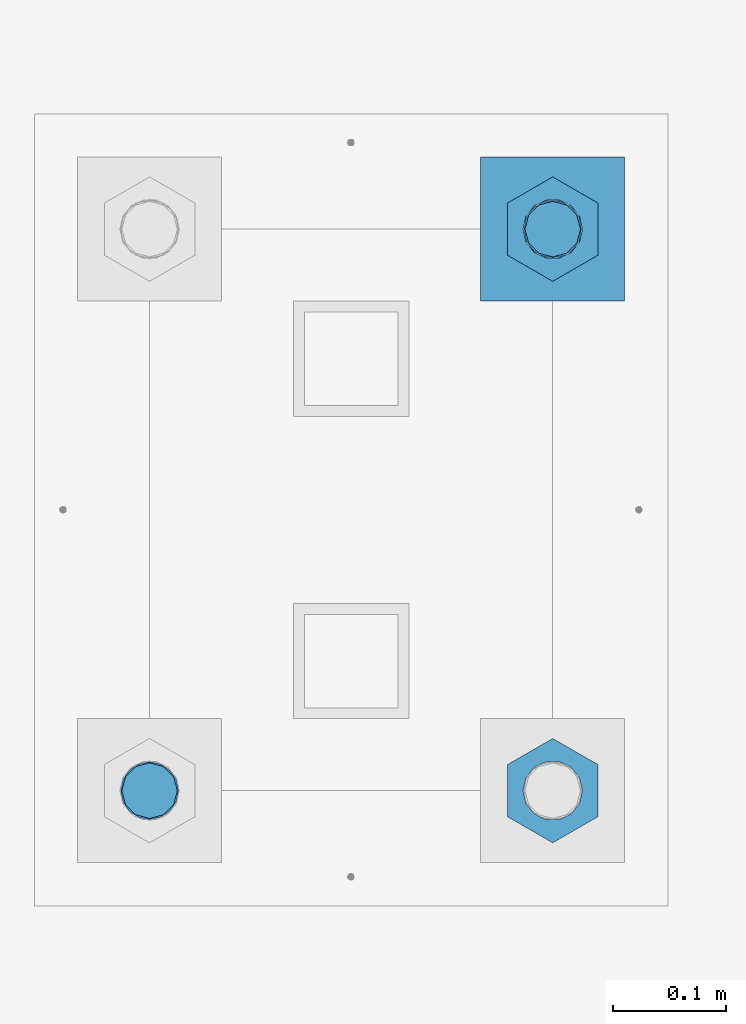
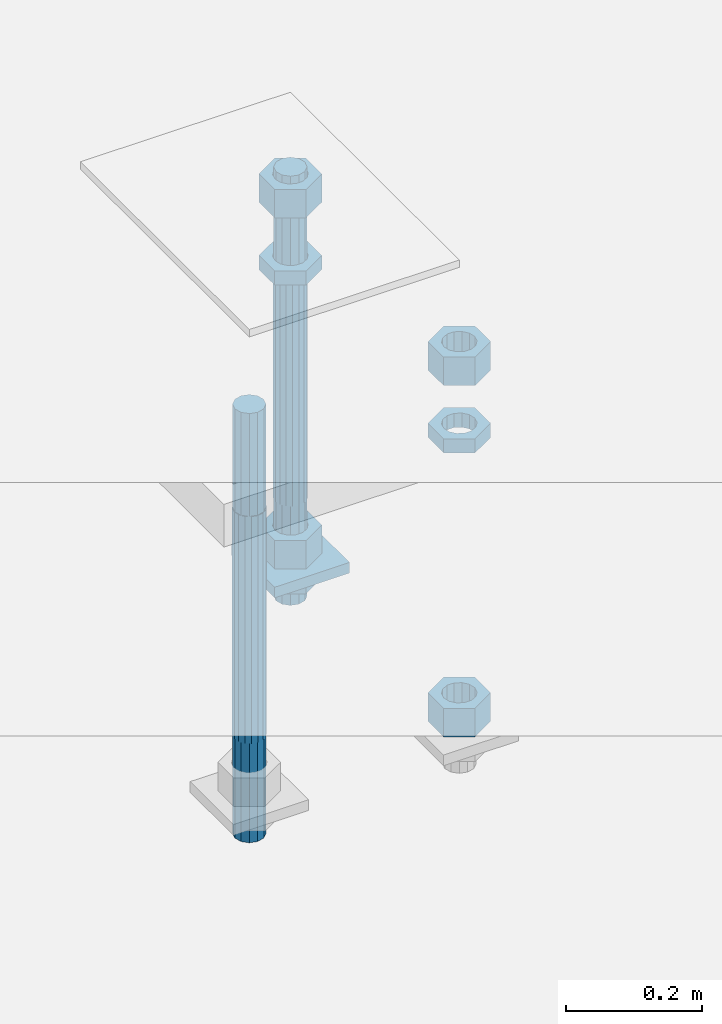
# One storey, part 2614 of 3843: 10 beams, 1 element without a shape of its own.
"""IFC2X3 building model written with IfcOpenShell, lengths in millimetres."""

from ifc_helpers import new_model, si_unit, frame, origin_with_axes, place, context, subcontext, project, spatial, faceted_brep, material, type_object, element, aggregate, save


model = new_model("IFC2X3")

# Units and contexts
model_context = context("Model", 3, precision=1e-05, world=origin_with_axes())
body_context = subcontext(model_context, "Body", "Model", "MODEL_VIEW")
ifc_project = project(units=[si_unit("LENGTHUNIT", "METRE", prefix="MILLI"), si_unit("AREAUNIT", "SQUARE_METRE"), si_unit("VOLUMEUNIT", "CUBIC_METRE"), si_unit("MASSUNIT", "GRAM", prefix="KILO"), si_unit("TIMEUNIT", "SECOND"), si_unit("PLANEANGLEUNIT", "RADIAN"), si_unit("SOLIDANGLEUNIT", "STERADIAN"), si_unit("THERMODYNAMICTEMPERATUREUNIT", "DEGREE_CELSIUS"), si_unit("LUMINOUSINTENSITYUNIT", "LUMEN")], contexts=[model_context])

# Site, building, storey
site_placement = place(None, origin_with_axes())
site = spatial("IfcSite", under=ifc_project, at=site_placement, CompositionType="ELEMENT")
building_placement = place(site_placement, origin_with_axes())
building = spatial("IfcBuilding", under=site, at=building_placement, Name="Undefined", CompositionType="ELEMENT")
storey_placement = place(building_placement, origin_with_axes())
storey = spatial("IfcBuildingStorey", under=building, at=storey_placement, Name="Undefined", CompositionType="ELEMENT", Elevation=0.0)

# Assembly, beams
assembly_placement = place(storey_placement, origin_with_axes())
assembly = element("IfcElementAssembly", 1, at=assembly_placement, inside=storey, Name="TEMPLATE", AssemblyPlace="NOTDEFINED", PredefinedType="RIGID_FRAME")
ifc_material_1 = material(Name="STEEL/A572-50")
beam_type_1 = type_object("IfcBeamType", PredefinedType="NOTDEFINED")
beam_1_placement = place(assembly_placement, frame((112153.700001526, 247.649999999994, 29244.925), z_axis=(0.0, -1.0, 0.0), x_axis=(1.0, 0.0, 0.0)))
beam_1 = element("IfcBeam", 2, at=beam_1_placement, type_object=beam_type_1, material=ifc_material_1, Name="WASHER_PLATE", context=body_context, shape_type="Brep", body=[
    faceted_brep([(0.0, 9.52500000000146, -63.5), (0.0, 9.52500000000146, 63.5), (127.0, 9.52500000000146, 63.5), (127.0, 9.52500000000146, -63.5), (0.0, -9.52500000000146, 63.5), (127.0, -9.52500000000146, 63.5), (0.0, -9.52500000000146, -63.5), (127.0, -9.52500000000146, -63.5)], [[[0, 1, 2, 3]], [[1, 4, 5, 2]], [[4, 6, 7, 5]], [[6, 0, 3, 7]], [[5, 7, 3, 2]], [[6, 4, 1, 0]]]),
])
ifc_material_2 = material(Name="STEEL/A36")
beam_type_2 = type_object("IfcBeamType", Name="2_HALF_NUT", PredefinedType="NOTDEFINED")
beam_2_placement = place(assembly_placement, frame((112217.200001526, 247.649999999994, 29787.85), z_axis=(1.0, 0.0, 0.0), x_axis=(0.0, 0.0, -1.0)))
beam_2 = element("IfcBeam", 3, at=beam_2_placement, type_object=beam_type_2, material=ifc_material_2, Name="NUT", ObjectType="2_HALF_NUT", context=body_context, shape_type="Brep", body=[
    faceted_brep([(0.0, -46.0369987487793, 0.0), (0.0, -23.0184993743896, -39.869213104248), (25.4000000000015, -23.0184993743896, -39.869213104248), (25.4000000000015, -46.0369987487793, 0.0), (0.0, 23.0184993743896, -39.869213104248), (25.4000000000015, 23.0184993743896, -39.869213104248), (0.0, 46.0369987487793, 0.0), (25.4000000000015, 46.0369987487793, 0.0), (0.0, 23.0184993743896, 39.869213104248), (25.4000000000015, 23.0184993743896, 39.869213104248), (0.0, -23.0184993743896, 39.869213104248), (25.4000000000015, -23.0184993743896, 39.869213104248), (0.0, 0.0, 26.1940002441406), (0.0, 11.3650617044477, 23.5999013092805), (25.4000000000015, 11.3650617044477, 23.5999013092805), (25.4000000000015, 0.0, 26.1940002441406), (0.0, 20.4791109456419, 16.3316083006721), (25.4000000000015, 20.4791109456419, 16.3316083006721), (0.0, 25.5370200498292, 5.82867859874386), (25.4000000000015, 25.5370200498292, 5.82867859874386), (0.0, 25.5370200498292, -5.82867859874386), (25.4000000000015, 25.5370200498292, -5.82867859874386), (0.0, 20.4791109456419, -16.3316083006721), (25.4000000000015, 20.4791109456419, -16.3316083006721), (0.0, 11.3650617044477, -23.5999013092805), (25.4000000000015, 11.3650617044477, -23.5999013092805), (0.0, 0.0, -26.1940002441406), (25.4000000000015, 0.0, -26.1940002441406), (0.0, -11.3650617044477, -23.5999013092805), (25.4000000000015, -11.3650617044477, -23.5999013092805), (0.0, -20.4791109456419, -16.3316083006721), (25.4000000000015, -20.4791109456419, -16.3316083006721), (0.0, -25.5370200498292, -5.82867859874386), (25.4000000000015, -25.5370200498292, -5.82867859874386), (0.0, -25.5370200498292, 5.82867859874386), (25.4000000000015, -25.5370200498292, 5.82867859874386), (0.0, -20.4791109456419, 16.3316083006721), (25.4000000000015, -20.4791109456419, 16.3316083006721), (0.0, -11.3650617044477, 23.5999013092805), (25.4000000000015, -11.3650617044477, 23.5999013092805)], [[[0, 1, 2, 3]], [[1, 4, 5, 2]], [[4, 6, 7, 5]], [[6, 8, 9, 7]], [[8, 10, 11, 9]], [[10, 0, 3, 11]], [[12, 13, 14, 15]], [[13, 16, 17, 14]], [[16, 18, 19, 17]], [[18, 20, 21, 19]], [[20, 22, 23, 21]], [[22, 24, 25, 23]], [[24, 26, 27, 25]], [[26, 28, 29, 27]], [[28, 30, 31, 29]], [[30, 32, 33, 31]], [[32, 34, 35, 33]], [[34, 36, 37, 35]], [[36, 38, 39, 37]], [[38, 12, 15, 39]], [[5, 7, 9, 11, 3, 2], [17, 19, 21, 23, 25, 27, 29, 31, 33, 35, 37, 39, 15, 14]], [[10, 8, 6, 4, 1, 0], [38, 36, 34, 32, 30, 28, 26, 24, 22, 20, 18, 16, 13, 12]]]),
])
beam_3_placement = place(assembly_placement, frame((112217.200001526, 247.649999999994, 29235.4), z_axis=(1.0, 0.0, 0.0), x_axis=(0.0, 0.0, -1.0)))
beam_3 = element("IfcBeam", 4, at=beam_3_placement, type_object=beam_type_2, material=ifc_material_2, Name="NUT", ObjectType="2_HALF_NUT", context=body_context, shape_type="Brep", body=[
    faceted_brep([(0.0, -46.0369987487793, 0.0), (0.0, -23.0184993743896, -39.869213104248), (25.4000000000015, -23.0184993743896, -39.869213104248), (25.4000000000015, -46.0369987487793, 0.0), (0.0, 23.0184993743896, -39.869213104248), (25.4000000000015, 23.0184993743896, -39.869213104248), (0.0, 46.0369987487793, 0.0), (25.4000000000015, 46.0369987487793, 0.0), (0.0, 23.0184993743896, 39.869213104248), (25.4000000000015, 23.0184993743896, 39.869213104248), (0.0, -23.0184993743896, 39.869213104248), (25.4000000000015, -23.0184993743896, 39.869213104248), (0.0, 0.0, 26.1940002441406), (0.0, 11.3650617044477, 23.5999013092805), (25.4000000000015, 11.3650617044477, 23.5999013092805), (25.4000000000015, 0.0, 26.1940002441406), (0.0, 20.4791109456419, 16.3316083006721), (25.4000000000015, 20.4791109456419, 16.3316083006721), (0.0, 25.5370200498292, 5.82867859874386), (25.4000000000015, 25.5370200498292, 5.82867859874386), (0.0, 25.5370200498292, -5.82867859874386), (25.4000000000015, 25.5370200498292, -5.82867859874386), (0.0, 20.4791109456419, -16.3316083006721), (25.4000000000015, 20.4791109456419, -16.3316083006721), (0.0, 11.3650617044477, -23.5999013092805), (25.4000000000015, 11.3650617044477, -23.5999013092805), (0.0, 0.0, -26.1940002441406), (25.4000000000015, 0.0, -26.1940002441406), (0.0, -11.3650617044477, -23.5999013092805), (25.4000000000015, -11.3650617044477, -23.5999013092805), (0.0, -20.4791109456419, -16.3316083006721), (25.4000000000015, -20.4791109456419, -16.3316083006721), (0.0, -25.5370200498292, -5.82867859874386), (25.4000000000015, -25.5370200498292, -5.82867859874386), (0.0, -25.5370200498292, 5.82867859874386), (25.4000000000015, -25.5370200498292, 5.82867859874386), (0.0, -20.4791109456419, 16.3316083006721), (25.4000000000015, -20.4791109456419, 16.3316083006721), (0.0, -11.3650617044477, 23.5999013092805), (25.4000000000015, -11.3650617044477, 23.5999013092805)], [[[0, 1, 2, 3]], [[1, 4, 5, 2]], [[4, 6, 7, 5]], [[6, 8, 9, 7]], [[8, 10, 11, 9]], [[10, 0, 3, 11]], [[12, 13, 14, 15]], [[13, 16, 17, 14]], [[16, 18, 19, 17]], [[18, 20, 21, 19]], [[20, 22, 23, 21]], [[22, 24, 25, 23]], [[24, 26, 27, 25]], [[26, 28, 29, 27]], [[28, 30, 31, 29]], [[30, 32, 33, 31]], [[32, 34, 35, 33]], [[34, 36, 37, 35]], [[36, 38, 39, 37]], [[38, 12, 15, 39]], [[5, 7, 9, 11, 3, 2], [17, 19, 21, 23, 25, 27, 29, 31, 33, 35, 37, 39, 15, 14]], [[10, 8, 6, 4, 1, 0], [38, 36, 34, 32, 30, 28, 26, 24, 22, 20, 18, 16, 13, 12]]]),
])
beam_4_placement = place(assembly_placement, frame((112217.200001526, -247.649999999994, 29787.85), z_axis=(1.0, 0.0, 0.0), x_axis=(0.0, 0.0, -1.0)))
beam_4 = element("IfcBeam", 5, at=beam_4_placement, type_object=beam_type_2, material=ifc_material_2, Name="NUT", ObjectType="2_HALF_NUT", context=body_context, shape_type="Brep", body=[
    faceted_brep([(0.0, -46.0369987487793, 0.0), (0.0, -23.0184993743896, -39.869213104248), (25.4000000000015, -23.0184993743896, -39.869213104248), (25.4000000000015, -46.0369987487793, 0.0), (0.0, 23.0184993743896, -39.869213104248), (25.4000000000015, 23.0184993743896, -39.869213104248), (0.0, 46.0369987487793, 0.0), (25.4000000000015, 46.0369987487793, 0.0), (0.0, 23.0184993743896, 39.869213104248), (25.4000000000015, 23.0184993743896, 39.869213104248), (0.0, -23.0184993743896, 39.869213104248), (25.4000000000015, -23.0184993743896, 39.869213104248), (0.0, 0.0, 26.1940002441406), (0.0, 11.3650617044477, 23.5999013092805), (25.4000000000015, 11.3650617044477, 23.5999013092805), (25.4000000000015, 0.0, 26.1940002441406), (0.0, 20.4791109456419, 16.3316083006721), (25.4000000000015, 20.4791109456419, 16.3316083006721), (0.0, 25.5370200498292, 5.82867859874386), (25.4000000000015, 25.5370200498292, 5.82867859874386), (0.0, 25.5370200498292, -5.82867859874386), (25.4000000000015, 25.5370200498292, -5.82867859874386), (0.0, 20.4791109456419, -16.3316083006721), (25.4000000000015, 20.4791109456419, -16.3316083006721), (0.0, 11.3650617044477, -23.5999013092805), (25.4000000000015, 11.3650617044477, -23.5999013092805), (0.0, 0.0, -26.1940002441406), (25.4000000000015, 0.0, -26.1940002441406), (0.0, -11.3650617044477, -23.5999013092805), (25.4000000000015, -11.3650617044477, -23.5999013092805), (0.0, -20.4791109456419, -16.3316083006721), (25.4000000000015, -20.4791109456419, -16.3316083006721), (0.0, -25.5370200498292, -5.82867859874386), (25.4000000000015, -25.5370200498292, -5.82867859874386), (0.0, -25.5370200498292, 5.82867859874386), (25.4000000000015, -25.5370200498292, 5.82867859874386), (0.0, -20.4791109456419, 16.3316083006721), (25.4000000000015, -20.4791109456419, 16.3316083006721), (0.0, -11.3650617044477, 23.5999013092805), (25.4000000000015, -11.3650617044477, 23.5999013092805)], [[[0, 1, 2, 3]], [[1, 4, 5, 2]], [[4, 6, 7, 5]], [[6, 8, 9, 7]], [[8, 10, 11, 9]], [[10, 0, 3, 11]], [[12, 13, 14, 15]], [[13, 16, 17, 14]], [[16, 18, 19, 17]], [[18, 20, 21, 19]], [[20, 22, 23, 21]], [[22, 24, 25, 23]], [[24, 26, 27, 25]], [[26, 28, 29, 27]], [[28, 30, 31, 29]], [[30, 32, 33, 31]], [[32, 34, 35, 33]], [[34, 36, 37, 35]], [[36, 38, 39, 37]], [[38, 12, 15, 39]], [[5, 7, 9, 11, 3, 2], [17, 19, 21, 23, 25, 27, 29, 31, 33, 35, 37, 39, 15, 14]], [[10, 8, 6, 4, 1, 0], [38, 36, 34, 32, 30, 28, 26, 24, 22, 20, 18, 16, 13, 12]]]),
])
beam_type_3 = type_object("IfcBeamType", Name="2_HEAVY_HEX_NUT", PredefinedType="NOTDEFINED")
beam_5_placement = place(assembly_placement, frame((112217.200001526, 247.649999999994, 29933.9), z_axis=(1.0, 0.0, 0.0), x_axis=(0.0, 0.0, -1.0)))
beam_5 = element("IfcBeam", 6, at=beam_5_placement, type_object=beam_type_3, material=ifc_material_2, Name="NUT", ObjectType="2_HEAVY_HEX_NUT", context=body_context, shape_type="Brep", body=[
    faceted_brep([(0.0, -46.0369987487793, 0.0), (0.0, -23.0184993743896, -39.869213104248), (50.7999999999993, -23.0184993743896, -39.869213104248), (50.7999999999993, -46.0369987487793, 0.0), (0.0, 23.0184993743896, -39.869213104248), (50.7999999999993, 23.0184993743896, -39.869213104248), (0.0, 46.0369987487793, 0.0), (50.7999999999993, 46.0369987487793, 0.0), (0.0, 23.0184993743896, 39.869213104248), (50.7999999999993, 23.0184993743896, 39.869213104248), (0.0, -23.0184993743896, 39.869213104248), (50.7999999999993, -23.0184993743896, 39.869213104248), (0.0, 0.0, 26.1940002441406), (0.0, 11.3650617044477, 23.5999013092805), (50.7999999999993, 11.3650617044477, 23.5999013092805), (50.7999999999993, 0.0, 26.1940002441406), (0.0, 20.4791109456419, 16.3316083006721), (50.7999999999993, 20.4791109456419, 16.3316083006721), (0.0, 25.5370200498292, 5.82867859874386), (50.7999999999993, 25.5370200498292, 5.82867859874386), (0.0, 25.5370200498292, -5.82867859874386), (50.7999999999993, 25.5370200498292, -5.82867859874386), (0.0, 20.4791109456419, -16.3316083006721), (50.7999999999993, 20.4791109456419, -16.3316083006721), (0.0, 11.3650617044477, -23.5999013092805), (50.7999999999993, 11.3650617044477, -23.5999013092805), (0.0, 0.0, -26.1940002441406), (50.7999999999993, 0.0, -26.1940002441406), (0.0, -11.3650617044477, -23.5999013092805), (50.7999999999993, -11.3650617044477, -23.5999013092805), (0.0, -20.4791109456419, -16.3316083006721), (50.7999999999993, -20.4791109456419, -16.3316083006721), (0.0, -25.5370200498292, -5.82867859874386), (50.7999999999993, -25.5370200498292, -5.82867859874386), (0.0, -25.5370200498292, 5.82867859874386), (50.7999999999993, -25.5370200498292, 5.82867859874386), (0.0, -20.4791109456419, 16.3316083006721), (50.7999999999993, -20.4791109456419, 16.3316083006721), (0.0, -11.3650617044477, 23.5999013092805), (50.7999999999993, -11.3650617044477, 23.5999013092805)], [[[0, 1, 2, 3]], [[1, 4, 5, 2]], [[4, 6, 7, 5]], [[6, 8, 9, 7]], [[8, 10, 11, 9]], [[10, 0, 3, 11]], [[12, 13, 14, 15]], [[13, 16, 17, 14]], [[16, 18, 19, 17]], [[18, 20, 21, 19]], [[20, 22, 23, 21]], [[22, 24, 25, 23]], [[24, 26, 27, 25]], [[26, 28, 29, 27]], [[28, 30, 31, 29]], [[30, 32, 33, 31]], [[32, 34, 35, 33]], [[34, 36, 37, 35]], [[36, 38, 39, 37]], [[38, 12, 15, 39]], [[5, 7, 9, 11, 3, 2], [17, 19, 21, 23, 25, 27, 29, 31, 33, 35, 37, 39, 15, 14]], [[10, 8, 6, 4, 1, 0], [38, 36, 34, 32, 30, 28, 26, 24, 22, 20, 18, 16, 13, 12]]]),
])
beam_6_placement = place(assembly_placement, frame((112217.200001526, 247.649999999994, 29305.25), z_axis=(1.0, 0.0, 0.0), x_axis=(0.0, 0.0, -1.0)))
beam_6 = element("IfcBeam", 7, at=beam_6_placement, type_object=beam_type_3, material=ifc_material_2, Name="NUT", ObjectType="2_HEAVY_HEX_NUT", context=body_context, shape_type="Brep", body=[
    faceted_brep([(0.0, -46.0369987487793, 0.0), (0.0, -23.0184993743896, -39.869213104248), (50.7999999999993, -23.0184993743896, -39.869213104248), (50.7999999999993, -46.0369987487793, 0.0), (0.0, 23.0184993743896, -39.869213104248), (50.7999999999993, 23.0184993743896, -39.869213104248), (0.0, 46.0369987487793, 0.0), (50.7999999999993, 46.0369987487793, 0.0), (0.0, 23.0184993743896, 39.869213104248), (50.7999999999993, 23.0184993743896, 39.869213104248), (0.0, -23.0184993743896, 39.869213104248), (50.7999999999993, -23.0184993743896, 39.869213104248), (0.0, 0.0, 26.1940002441406), (0.0, 11.3650617044477, 23.5999013092805), (50.7999999999993, 11.3650617044477, 23.5999013092805), (50.7999999999993, 0.0, 26.1940002441406), (0.0, 20.4791109456419, 16.3316083006721), (50.7999999999993, 20.4791109456419, 16.3316083006721), (0.0, 25.5370200498292, 5.82867859874386), (50.7999999999993, 25.5370200498292, 5.82867859874386), (0.0, 25.5370200498292, -5.82867859874386), (50.7999999999993, 25.5370200498292, -5.82867859874386), (0.0, 20.4791109456419, -16.3316083006721), (50.7999999999993, 20.4791109456419, -16.3316083006721), (0.0, 11.3650617044477, -23.5999013092805), (50.7999999999993, 11.3650617044477, -23.5999013092805), (0.0, 0.0, -26.1940002441406), (50.7999999999993, 0.0, -26.1940002441406), (0.0, -11.3650617044477, -23.5999013092805), (50.7999999999993, -11.3650617044477, -23.5999013092805), (0.0, -20.4791109456419, -16.3316083006721), (50.7999999999993, -20.4791109456419, -16.3316083006721), (0.0, -25.5370200498292, -5.82867859874386), (50.7999999999993, -25.5370200498292, -5.82867859874386), (0.0, -25.5370200498292, 5.82867859874386), (50.7999999999993, -25.5370200498292, 5.82867859874386), (0.0, -20.4791109456419, 16.3316083006721), (50.7999999999993, -20.4791109456419, 16.3316083006721), (0.0, -11.3650617044477, 23.5999013092805), (50.7999999999993, -11.3650617044477, 23.5999013092805)], [[[0, 1, 2, 3]], [[1, 4, 5, 2]], [[4, 6, 7, 5]], [[6, 8, 9, 7]], [[8, 10, 11, 9]], [[10, 0, 3, 11]], [[12, 13, 14, 15]], [[13, 16, 17, 14]], [[16, 18, 19, 17]], [[18, 20, 21, 19]], [[20, 22, 23, 21]], [[22, 24, 25, 23]], [[24, 26, 27, 25]], [[26, 28, 29, 27]], [[28, 30, 31, 29]], [[30, 32, 33, 31]], [[32, 34, 35, 33]], [[34, 36, 37, 35]], [[36, 38, 39, 37]], [[38, 12, 15, 39]], [[5, 7, 9, 11, 3, 2], [17, 19, 21, 23, 25, 27, 29, 31, 33, 35, 37, 39, 15, 14]], [[10, 8, 6, 4, 1, 0], [38, 36, 34, 32, 30, 28, 26, 24, 22, 20, 18, 16, 13, 12]]]),
])
beam_7_placement = place(assembly_placement, frame((112217.200001526, -247.649999999994, 29933.9), z_axis=(1.0, 0.0, 0.0), x_axis=(0.0, 0.0, -1.0)))
beam_7 = element("IfcBeam", 8, at=beam_7_placement, type_object=beam_type_3, material=ifc_material_2, Name="NUT", ObjectType="2_HEAVY_HEX_NUT", context=body_context, shape_type="Brep", body=[
    faceted_brep([(0.0, -46.0369987487793, 0.0), (0.0, -23.0184993743896, -39.869213104248), (50.7999999999993, -23.0184993743896, -39.869213104248), (50.7999999999993, -46.0369987487793, 0.0), (0.0, 23.0184993743896, -39.869213104248), (50.7999999999993, 23.0184993743896, -39.869213104248), (0.0, 46.0369987487793, 0.0), (50.7999999999993, 46.0369987487793, 0.0), (0.0, 23.0184993743896, 39.869213104248), (50.7999999999993, 23.0184993743896, 39.869213104248), (0.0, -23.0184993743896, 39.869213104248), (50.7999999999993, -23.0184993743896, 39.869213104248), (0.0, 0.0, 26.1940002441406), (0.0, 11.3650617044477, 23.5999013092805), (50.7999999999993, 11.3650617044477, 23.5999013092805), (50.7999999999993, 0.0, 26.1940002441406), (0.0, 20.4791109456419, 16.3316083006721), (50.7999999999993, 20.4791109456419, 16.3316083006721), (0.0, 25.5370200498292, 5.82867859874386), (50.7999999999993, 25.5370200498292, 5.82867859874386), (0.0, 25.5370200498292, -5.82867859874386), (50.7999999999993, 25.5370200498292, -5.82867859874386), (0.0, 20.4791109456419, -16.3316083006721), (50.7999999999993, 20.4791109456419, -16.3316083006721), (0.0, 11.3650617044477, -23.5999013092805), (50.7999999999993, 11.3650617044477, -23.5999013092805), (0.0, 0.0, -26.1940002441406), (50.7999999999993, 0.0, -26.1940002441406), (0.0, -11.3650617044477, -23.5999013092805), (50.7999999999993, -11.3650617044477, -23.5999013092805), (0.0, -20.4791109456419, -16.3316083006721), (50.7999999999993, -20.4791109456419, -16.3316083006721), (0.0, -25.5370200498292, -5.82867859874386), (50.7999999999993, -25.5370200498292, -5.82867859874386), (0.0, -25.5370200498292, 5.82867859874386), (50.7999999999993, -25.5370200498292, 5.82867859874386), (0.0, -20.4791109456419, 16.3316083006721), (50.7999999999993, -20.4791109456419, 16.3316083006721), (0.0, -11.3650617044477, 23.5999013092805), (50.7999999999993, -11.3650617044477, 23.5999013092805)], [[[0, 1, 2, 3]], [[1, 4, 5, 2]], [[4, 6, 7, 5]], [[6, 8, 9, 7]], [[8, 10, 11, 9]], [[10, 0, 3, 11]], [[12, 13, 14, 15]], [[13, 16, 17, 14]], [[16, 18, 19, 17]], [[18, 20, 21, 19]], [[20, 22, 23, 21]], [[22, 24, 25, 23]], [[24, 26, 27, 25]], [[26, 28, 29, 27]], [[28, 30, 31, 29]], [[30, 32, 33, 31]], [[32, 34, 35, 33]], [[34, 36, 37, 35]], [[36, 38, 39, 37]], [[38, 12, 15, 39]], [[5, 7, 9, 11, 3, 2], [17, 19, 21, 23, 25, 27, 29, 31, 33, 35, 37, 39, 15, 14]], [[10, 8, 6, 4, 1, 0], [38, 36, 34, 32, 30, 28, 26, 24, 22, 20, 18, 16, 13, 12]]]),
])
beam_8_placement = place(assembly_placement, frame((112217.200001526, -247.649999999994, 29305.25), z_axis=(1.0, 0.0, 0.0), x_axis=(0.0, 0.0, -1.0)))
beam_8 = element("IfcBeam", 9, at=beam_8_placement, type_object=beam_type_3, material=ifc_material_2, Name="NUT", ObjectType="2_HEAVY_HEX_NUT", context=body_context, shape_type="Brep", body=[
    faceted_brep([(0.0, -46.0369987487793, 0.0), (0.0, -23.0184993743896, -39.869213104248), (50.7999999999993, -23.0184993743896, -39.869213104248), (50.7999999999993, -46.0369987487793, 0.0), (0.0, 23.0184993743896, -39.869213104248), (50.7999999999993, 23.0184993743896, -39.869213104248), (0.0, 46.0369987487793, 0.0), (50.7999999999993, 46.0369987487793, 0.0), (0.0, 23.0184993743896, 39.869213104248), (50.7999999999993, 23.0184993743896, 39.869213104248), (0.0, -23.0184993743896, 39.869213104248), (50.7999999999993, -23.0184993743896, 39.869213104248), (0.0, 0.0, 26.1940002441406), (0.0, 11.3650617044477, 23.5999013092805), (50.7999999999993, 11.3650617044477, 23.5999013092805), (50.7999999999993, 0.0, 26.1940002441406), (0.0, 20.4791109456419, 16.3316083006721), (50.7999999999993, 20.4791109456419, 16.3316083006721), (0.0, 25.5370200498292, 5.82867859874386), (50.7999999999993, 25.5370200498292, 5.82867859874386), (0.0, 25.5370200498292, -5.82867859874386), (50.7999999999993, 25.5370200498292, -5.82867859874386), (0.0, 20.4791109456419, -16.3316083006721), (50.7999999999993, 20.4791109456419, -16.3316083006721), (0.0, 11.3650617044477, -23.5999013092805), (50.7999999999993, 11.3650617044477, -23.5999013092805), (0.0, 0.0, -26.1940002441406), (50.7999999999993, 0.0, -26.1940002441406), (0.0, -11.3650617044477, -23.5999013092805), (50.7999999999993, -11.3650617044477, -23.5999013092805), (0.0, -20.4791109456419, -16.3316083006721), (50.7999999999993, -20.4791109456419, -16.3316083006721), (0.0, -25.5370200498292, -5.82867859874386), (50.7999999999993, -25.5370200498292, -5.82867859874386), (0.0, -25.5370200498292, 5.82867859874386), (50.7999999999993, -25.5370200498292, 5.82867859874386), (0.0, -20.4791109456419, 16.3316083006721), (50.7999999999993, -20.4791109456419, 16.3316083006721), (0.0, -11.3650617044477, 23.5999013092805), (50.7999999999993, -11.3650617044477, 23.5999013092805)], [[[0, 1, 2, 3]], [[1, 4, 5, 2]], [[4, 6, 7, 5]], [[6, 8, 9, 7]], [[8, 10, 11, 9]], [[10, 0, 3, 11]], [[12, 13, 14, 15]], [[13, 16, 17, 14]], [[16, 18, 19, 17]], [[18, 20, 21, 19]], [[20, 22, 23, 21]], [[22, 24, 25, 23]], [[24, 26, 27, 25]], [[26, 28, 29, 27]], [[28, 30, 31, 29]], [[30, 32, 33, 31]], [[32, 34, 35, 33]], [[34, 36, 37, 35]], [[36, 38, 39, 37]], [[38, 12, 15, 39]], [[5, 7, 9, 11, 3, 2], [17, 19, 21, 23, 25, 27, 29, 31, 33, 35, 37, 39, 15, 14]], [[10, 8, 6, 4, 1, 0], [38, 36, 34, 32, 30, 28, 26, 24, 22, 20, 18, 16, 13, 12]]]),
])
ifc_material_3 = material()
beam_type_4 = type_object("IfcBeamType", PredefinedType="NOTDEFINED")
beam_9_placement = place(assembly_placement, frame((111861.600001526, -247.649999999994, 29762.45), z_axis=(1.0, 0.0, 0.0), x_axis=(0.0, 0.0, -1.0)))
beam_9 = element("IfcBeam", 10, at=beam_9_placement, type_object=beam_type_4, material=ifc_material_3, Name="ANCHOR_ROD", context=body_context, shape_type="Brep", body=[
    faceted_brep([(-184.150000000001, -21.217622392709, 12.25), (-184.150000000001, -12.2499999999854, 21.2176223927163), (-184.150000000001, 1.45519152283669e-11, 24.5), (-184.150000000001, 12.2500000000146, 21.2176223927163), (-184.150000000001, 21.2176223927381, 12.25), (-184.150000000001, 24.5000000000146, 0.0), (-184.150000000001, 21.2176223927381, -12.25), (-184.150000000001, 12.2500000000146, -21.2176223927163), (-184.150000000001, 1.45519152283669e-11, -24.5), (-184.150000000001, -12.2499999999854, -21.2176223927163), (-184.150000000001, -21.217622392709, -12.25), (-184.150000000001, -24.4999999999854, 0.0), (0.0, 24.5000000000146, 0.0), (0.0, 21.2176223927381, -12.25), (0.0, 12.2500000000146, -21.2176223927163), (0.0, 1.45519152283669e-11, -24.5), (0.0, -12.2499999999854, -21.2176223927163), (0.0, -21.217622392709, -12.25), (0.0, -24.4999999999854, 0.0), (0.0, -21.217622392709, 12.25), (0.0, -12.2499999999854, 21.2176223927163), (0.0, 1.45519152283669e-11, 24.5), (0.0, 12.2500000000146, 21.2176223927163), (0.0, 21.2176223927381, 12.25), (0.0, -23.4665401257807, 9.72015918207035), (0.0, -17.9605122421344, 17.9605122421417), (0.0, -9.72015918207762, 23.466540125788), (0.0, 0.0, 25.4000000000015), (0.0, 9.72015918207762, 23.466540125788), (0.0, 17.9605122421344, 17.9605122421417), (0.0, 23.4665401257807, 9.72015918207035), (0.0, 25.3999996185303, 0.0), (0.0, 23.4665401257807, -9.72015918207035), (0.0, 17.9605122421344, -17.9605122421417), (0.0, 9.72015918207762, -23.466540125788), (0.0, 0.0, -25.4000000000015), (0.0, -9.72015918207762, -23.466540125788), (0.0, -17.9605122421344, -17.9605122421417), (0.0, -23.4665401257807, -9.72015918207035), (0.0, -25.3999996185303, 0.0), (406.399999999998, -25.3999999999942, 0.0), (406.399999999998, -23.4665401257807, 9.72015918207035), (406.399999999998, -17.9605122421344, 17.9605122421417), (406.399999999998, -9.72015918207762, 23.466540125788), (406.399999999998, 0.0, 25.4000000000015), (406.399999999998, 9.72015918207762, 23.466540125788), (406.399999999998, 17.9605122421344, 17.9605122421417), (406.399999999998, 23.4665401257807, 9.72015918207035), (406.399999999998, 25.3999999999942, 0.0), (406.399999999998, 23.4665401257807, -9.72015918207035), (406.399999999998, 17.9605122421344, -17.9605122421417), (406.399999999998, 9.72015918207762, -23.466540125788), (406.399999999998, 0.0, -25.4000000000015), (406.399999999998, -9.72015918207762, -23.466540125788), (406.399999999998, -17.9605122421344, -17.9605122421417), (406.399999999998, -23.4665401257807, -9.72015918207035), (406.399999999998, -12.2499999999854, 21.2176223927163), (406.399999999998, 1.45519152283669e-11, 24.5), (406.399999999998, 12.2500000000146, 21.2176223927163), (406.399999999998, 21.2176223927381, 12.25), (406.399999999998, 24.5000000000146, 0.0), (406.399999999998, 21.2176223927381, -12.25), (406.399999999998, 12.2500000000146, -21.2176223927163), (406.399999999998, 1.45519152283669e-11, -24.5), (406.399999999998, -12.2499999999854, -21.2176223927163), (406.399999999998, -21.217622392709, -12.25), (406.399999999998, -24.4999999999854, 0.0), (406.399999999998, -21.217622392709, 12.25), (584.200000000001, -12.2499999999854, -21.2176223927163), (584.200000000001, 1.45519152283669e-11, -24.5), (584.200000000001, 12.2500000000146, -21.2176223927163), (584.200000000001, 21.2176223927381, -12.25), (584.200000000001, 24.5000000000146, 0.0), (584.200000000001, 21.2176223927381, 12.25), (584.200000000001, 12.2500000000146, 21.2176223927163), (584.200000000001, 1.45519152283669e-11, 24.5), (584.200000000001, -12.2499999999854, 21.2176223927163), (584.200000000001, -21.217622392709, 12.25), (584.200000000001, -24.4999999999854, 0.0), (584.200000000001, -21.217622392709, -12.25)], [[[0, 1, 2, 3, 4, 5, 6, 7, 8, 9, 10, 11]], [[6, 5, 12, 13]], [[7, 6, 13, 14]], [[8, 7, 14, 15]], [[9, 8, 15, 16]], [[10, 9, 16, 17]], [[11, 10, 17, 18]], [[0, 11, 18, 19]], [[1, 0, 19, 20]], [[2, 1, 20, 21]], [[3, 2, 21, 22]], [[4, 3, 22, 23]], [[5, 4, 23, 12]], [[24, 25, 26, 27, 28, 29, 30, 31, 32, 33, 34, 35, 36, 37, 38, 39], [22, 21, 20, 19, 18, 17, 16, 15, 14, 13, 12, 23]], [[24, 39, 40, 41]], [[25, 24, 41, 42]], [[26, 25, 42, 43]], [[27, 26, 43, 44]], [[28, 27, 44, 45]], [[29, 28, 45, 46]], [[30, 29, 46, 47]], [[31, 30, 47, 48]], [[32, 31, 48, 49]], [[33, 32, 49, 50]], [[34, 33, 50, 51]], [[35, 34, 51, 52]], [[36, 35, 52, 53]], [[37, 36, 53, 54]], [[38, 37, 54, 55]], [[39, 38, 55, 40]], [[54, 53, 52, 51, 50, 49, 48, 47, 46, 45, 44, 43, 42, 41, 40, 55], [56, 57, 58, 59, 60, 61, 62, 63, 64, 65, 66, 67]], [[68, 69, 70, 71, 72, 73, 74, 75, 76, 77, 78, 79]], [[76, 75, 57, 56]], [[77, 76, 56, 67]], [[78, 77, 67, 66]], [[79, 78, 66, 65]], [[68, 79, 65, 64]], [[69, 68, 64, 63]], [[70, 69, 63, 62]], [[71, 70, 62, 61]], [[72, 71, 61, 60]], [[73, 72, 60, 59]], [[74, 73, 59, 58]], [[75, 74, 58, 57]]]),
])
beam_10_placement = place(assembly_placement, frame((112217.200001526, 247.649999999994, 29762.45), z_axis=(1.0, 0.0, 0.0), x_axis=(0.0, 0.0, -1.0)))
beam_10 = element("IfcBeam", 11, at=beam_10_placement, type_object=beam_type_4, material=ifc_material_3, Name="ANCHOR_ROD", context=body_context, shape_type="Brep", body=[
    faceted_brep([(-184.150000000001, -21.217622392709, 12.25), (-184.150000000001, -12.2499999999854, 21.2176223927163), (-184.150000000001, 1.45519152283669e-11, 24.5), (-184.150000000001, 12.2500000000146, 21.2176223927163), (-184.150000000001, 21.2176223927381, 12.25), (-184.150000000001, 24.5000000000146, 0.0), (-184.150000000001, 21.2176223927381, -12.25), (-184.150000000001, 12.2500000000146, -21.2176223927163), (-184.150000000001, 1.45519152283669e-11, -24.5), (-184.150000000001, -12.2499999999854, -21.2176223927163), (-184.150000000001, -21.217622392709, -12.25), (-184.150000000001, -24.4999999999854, 0.0), (0.0, 24.5000000000146, 0.0), (0.0, 21.2176223927381, -12.25), (0.0, 12.2500000000146, -21.2176223927163), (0.0, 1.45519152283669e-11, -24.5), (0.0, -12.2499999999854, -21.2176223927163), (0.0, -21.217622392709, -12.25), (0.0, -24.4999999999854, 0.0), (0.0, -21.217622392709, 12.25), (0.0, -12.2499999999854, 21.2176223927163), (0.0, 1.45519152283669e-11, 24.5), (0.0, 12.2500000000146, 21.2176223927163), (0.0, 21.2176223927381, 12.25), (0.0, -23.4665401257807, 9.72015918207035), (0.0, -17.9605122421344, 17.9605122421417), (0.0, -9.72015918207762, 23.466540125788), (0.0, 0.0, 25.4000000000015), (0.0, 9.72015918207762, 23.466540125788), (0.0, 17.9605122421344, 17.9605122421417), (0.0, 23.4665401257807, 9.72015918207035), (0.0, 25.3999996185303, 0.0), (0.0, 23.4665401257807, -9.72015918207035), (0.0, 17.9605122421344, -17.9605122421417), (0.0, 9.72015918207762, -23.466540125788), (0.0, 0.0, -25.4000000000015), (0.0, -9.72015918207762, -23.466540125788), (0.0, -17.9605122421344, -17.9605122421417), (0.0, -23.4665401257807, -9.72015918207035), (0.0, -25.3999996185303, 0.0), (406.399999999998, -25.3999999999942, 0.0), (406.399999999998, -23.4665401257807, 9.72015918207035), (406.399999999998, -17.9605122421344, 17.9605122421417), (406.399999999998, -9.72015918207762, 23.466540125788), (406.399999999998, 0.0, 25.4000000000015), (406.399999999998, 9.72015918207762, 23.466540125788), (406.399999999998, 17.9605122421344, 17.9605122421417), (406.399999999998, 23.4665401257807, 9.72015918207035), (406.399999999998, 25.3999999999942, 0.0), (406.399999999998, 23.4665401257807, -9.72015918207035), (406.399999999998, 17.9605122421344, -17.9605122421417), (406.399999999998, 9.72015918207762, -23.466540125788), (406.399999999998, 0.0, -25.4000000000015), (406.399999999998, -9.72015918207762, -23.466540125788), (406.399999999998, -17.9605122421344, -17.9605122421417), (406.399999999998, -23.4665401257807, -9.72015918207035), (406.399999999998, -12.2499999999854, 21.2176223927163), (406.399999999998, 1.45519152283669e-11, 24.5), (406.399999999998, 12.2500000000146, 21.2176223927163), (406.399999999998, 21.2176223927381, 12.25), (406.399999999998, 24.5000000000146, 0.0), (406.399999999998, 21.2176223927381, -12.25), (406.399999999998, 12.2500000000146, -21.2176223927163), (406.399999999998, 1.45519152283669e-11, -24.5), (406.399999999998, -12.2499999999854, -21.2176223927163), (406.399999999998, -21.217622392709, -12.25), (406.399999999998, -24.4999999999854, 0.0), (406.399999999998, -21.217622392709, 12.25), (584.200000000001, -12.2499999999854, -21.2176223927163), (584.200000000001, 1.45519152283669e-11, -24.5), (584.200000000001, 12.2500000000146, -21.2176223927163), (584.200000000001, 21.2176223927381, -12.25), (584.200000000001, 24.5000000000146, 0.0), (584.200000000001, 21.2176223927381, 12.25), (584.200000000001, 12.2500000000146, 21.2176223927163), (584.200000000001, 1.45519152283669e-11, 24.5), (584.200000000001, -12.2499999999854, 21.2176223927163), (584.200000000001, -21.217622392709, 12.25), (584.200000000001, -24.4999999999854, 0.0), (584.200000000001, -21.217622392709, -12.25)], [[[0, 1, 2, 3, 4, 5, 6, 7, 8, 9, 10, 11]], [[6, 5, 12, 13]], [[7, 6, 13, 14]], [[8, 7, 14, 15]], [[9, 8, 15, 16]], [[10, 9, 16, 17]], [[11, 10, 17, 18]], [[0, 11, 18, 19]], [[1, 0, 19, 20]], [[2, 1, 20, 21]], [[3, 2, 21, 22]], [[4, 3, 22, 23]], [[5, 4, 23, 12]], [[24, 25, 26, 27, 28, 29, 30, 31, 32, 33, 34, 35, 36, 37, 38, 39], [22, 21, 20, 19, 18, 17, 16, 15, 14, 13, 12, 23]], [[24, 39, 40, 41]], [[25, 24, 41, 42]], [[26, 25, 42, 43]], [[27, 26, 43, 44]], [[28, 27, 44, 45]], [[29, 28, 45, 46]], [[30, 29, 46, 47]], [[31, 30, 47, 48]], [[32, 31, 48, 49]], [[33, 32, 49, 50]], [[34, 33, 50, 51]], [[35, 34, 51, 52]], [[36, 35, 52, 53]], [[37, 36, 53, 54]], [[38, 37, 54, 55]], [[39, 38, 55, 40]], [[54, 53, 52, 51, 50, 49, 48, 47, 46, 45, 44, 43, 42, 41, 40, 55], [56, 57, 58, 59, 60, 61, 62, 63, 64, 65, 66, 67]], [[68, 69, 70, 71, 72, 73, 74, 75, 76, 77, 78, 79]], [[76, 75, 57, 56]], [[77, 76, 56, 67]], [[78, 77, 67, 66]], [[79, 78, 66, 65]], [[68, 79, 65, 64]], [[69, 68, 64, 63]], [[70, 69, 63, 62]], [[71, 70, 62, 61]], [[72, 71, 61, 60]], [[73, 72, 60, 59]], [[74, 73, 59, 58]], [[75, 74, 58, 57]]]),
])
aggregate(assembly, [beam_9, beam_2, beam_5, beam_6, beam_3, beam_1, beam_10, beam_4, beam_7, beam_8])

save(model, "model.ifc")
